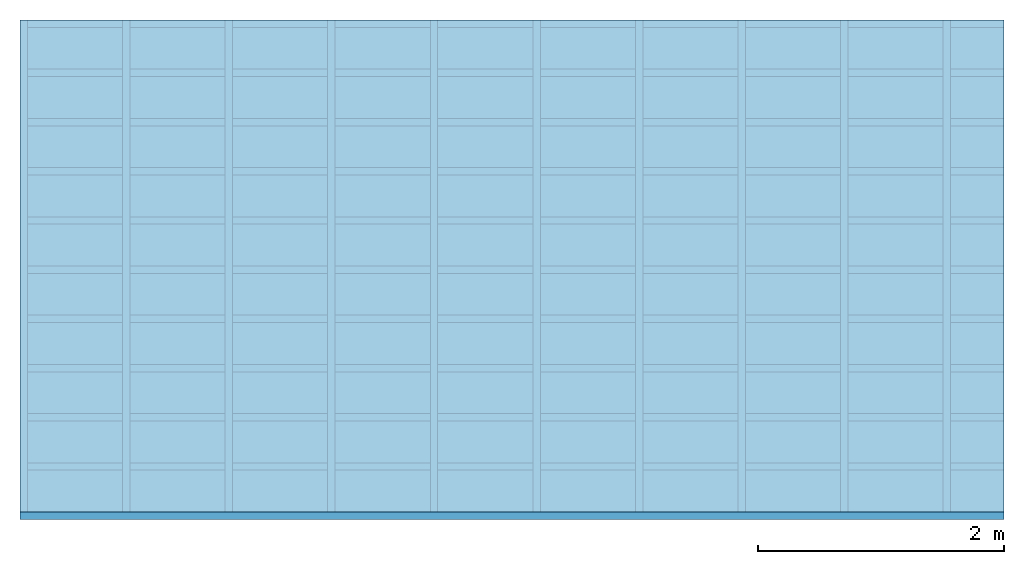
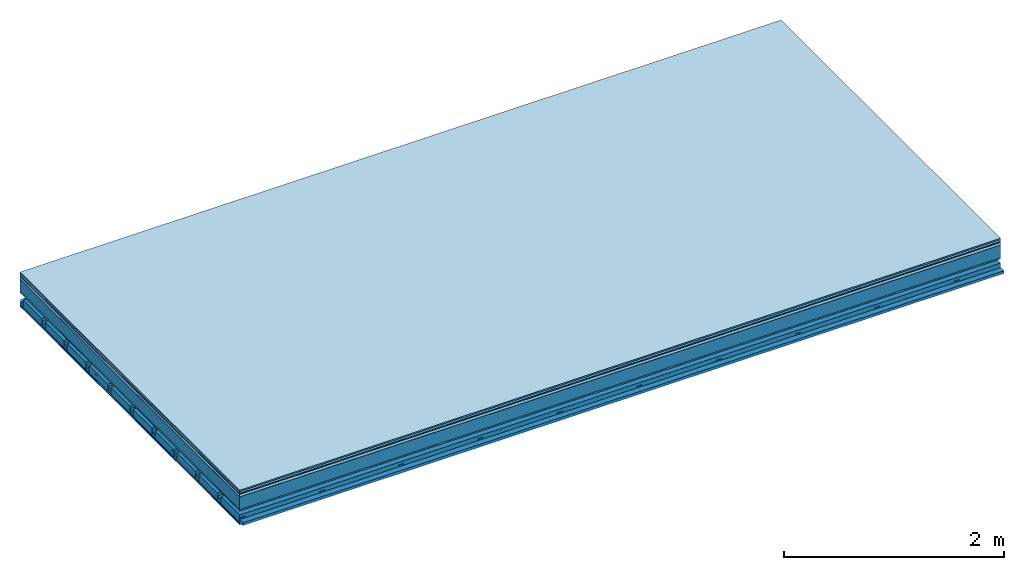
# One storey: 9 plates, 4 members, 1 element without a shape of its own.
"""IFC4 building model written with IfcOpenShell, lengths in metres."""

from ifc_helpers import new_model, si_unit, derived_unit, direction, frame, frame_2d, origin, origin_with_axes, place, context, project, spatial, polyline, rectangle, outline, extrude, material, layer, layer_set, type_object, element, aggregate, save


model = new_model("IFC4")

# Units and contexts
plan_context = context("Plan", 3, precision=1e-05, world=origin(), true_north=direction((0.0, 1.0)))
model_context = context("Model", 3, precision=1e-05, world=origin(), true_north=direction((0.0, 1.0)))
ifc_project = project(units=[si_unit("LENGTHUNIT", "METRE"), derived_unit("SOUNDPRESSUREUNIT", [(si_unit("PRESSUREUNIT", "PASCAL", prefix="MICRO"), 0)]), si_unit("ENERGYUNIT", "JOULE", prefix="MEGA"), si_unit("MASSUNIT", "GRAM", prefix="KILO"), derived_unit("THERMALTRANSMITTANCEUNIT", [(si_unit("POWERUNIT", "WATT"), 1), (si_unit("AREAUNIT", "SQUARE_METRE"), -1), (si_unit("THERMODYNAMICTEMPERATUREUNIT", "KELVIN"), -1)]), derived_unit("AREADENSITYUNIT", [(si_unit("MASSUNIT", "GRAM", prefix="KILO"), 1), (si_unit("AREAUNIT", "SQUARE_METRE"), -1)]), derived_unit("USERDEFINED", [(si_unit("ENERGYUNIT", "JOULE", prefix="MEGA"), 1), (si_unit("AREAUNIT", "SQUARE_METRE"), -1)])], contexts=[plan_context, model_context])

# Site, building, storey
site = spatial("IfcSite", under=ifc_project)
building_placement = place(None, origin())
building = spatial("IfcBuilding", under=site, at=building_placement)
storey_placement = place(building_placement, origin())
storey = spatial("IfcBuildingStorey", under=building, at=storey_placement)

# Slab, members, plates
ifc_material_1 = material(Category="11.013")
ifc_layer_1 = layer(ifc_material_1, 0.015, Name="Flooring")
ifc_material_2 = material(Category="03.007")
ifc_layer_2 = layer(ifc_material_2, 0.02, Name="On-material")
ifc_material_3 = material(Name="Wood fiber generic product", Category="10.009")
ifc_layer_3 = layer(ifc_material_3, 0.01, Name="Impact sound insulation")
ifc_material_4 = material(Name="with broken")
ifc_layer_4 = layer(ifc_material_4, 0.03, Name="on Supporting structure")
ifc_material_5 = material(Name="protection", Category="09.007")
ifc_layer_5 = layer(ifc_material_5, 0.0005, Name="Sub-floor")
ifc_material_6 = material(Name="no composite action")
ifc_layer_6 = layer(ifc_material_6, 0.0, Name="Bond")
ifc_layer_7 = layer(None, 0.14, Name="Supporting structure")
ifc_material_7 = material(Name="of the art")
ifc_layer_8 = layer(ifc_material_7, 0.0, Name="Bond")
ifc_layer_9 = layer(ifc_material_2, 0.015, Name="Lower layer 1")
ifc_layer_10 = layer(None, 0.095, Name="Coupling")
ifc_layer_11 = layer(None, 0.03, Name="Battens / profiles")
ifc_material_8 = material(Name="Plasterboard type A", Category="03.008")
ifc_layer_12 = layer(ifc_material_8, 0.0125, Name="Ceiling covering 1st layer")
ifc_layer_13 = layer(ifc_material_8, 0.0125, Name="Ceiling covering layer 2")
ifc_material_9 = material(Category="04.001")
ifc_layer_14 = layer(ifc_material_9, 0.003, Name="Surface / treatment")
ifc_layer_set = layer_set([ifc_layer_1, ifc_layer_2, ifc_layer_3, ifc_layer_4, ifc_layer_5, ifc_layer_6, ifc_layer_7, ifc_layer_8, ifc_layer_9, ifc_layer_10, ifc_layer_11, ifc_layer_12, ifc_layer_13, ifc_layer_14])
slab_type = type_object("IfcSlabType", Name="A2124", PredefinedType="NOTDEFINED", material=ifc_layer_set)
slab_placement = place(None, frame((0.0, 0.0, 0.0), z_axis=(0.0, 0.0, -1.0), x_axis=(1.0, 0.0, 0.0)))
slab = element("IfcSlab", 1, at=slab_placement, inside=storey, type_object=slab_type, material=ifc_layer_set, Name="Slab #1")
ifc_material_10 = material(Name="Solid timber panel")
member_1_placement = place(slab_placement, origin())
member_1 = element("IfcMember", 2, at=member_1_placement, material=ifc_material_10, Name="Supporting structure", context=plan_context, shape_type="SweptSolid", body=[
    extrude(rectangle(XDim=1.0, YDim=0.14, at=frame_2d((0.5, 0.07), x_axis=(1.0, 0.0))), frame((0.0, 4.0, 0.0755), z_axis=(0.0, -1.0, 0.0), x_axis=(1.0, 0.0, 0.0)), (0.0, 0.0, 1.0), 4.0),
    extrude(rectangle(XDim=1.0, YDim=0.14, at=frame_2d((0.5, 0.07), x_axis=(1.0, 0.0))), frame((1.0, 4.0, 0.0755), z_axis=(0.0, -1.0, 0.0), x_axis=(1.0, 0.0, 0.0)), (0.0, 0.0, 1.0), 4.0),
    extrude(rectangle(XDim=1.0, YDim=0.14, at=frame_2d((0.5, 0.07), x_axis=(1.0, 0.0))), frame((2.0, 4.0, 0.0755), z_axis=(0.0, -1.0, 0.0), x_axis=(1.0, 0.0, 0.0)), (0.0, 0.0, 1.0), 4.0),
    extrude(rectangle(XDim=1.0, YDim=0.14, at=frame_2d((0.5, 0.07), x_axis=(1.0, 0.0))), frame((3.0, 4.0, 0.0755), z_axis=(0.0, -1.0, 0.0), x_axis=(1.0, 0.0, 0.0)), (0.0, 0.0, 1.0), 4.0),
    extrude(rectangle(XDim=1.0, YDim=0.14, at=frame_2d((0.5, 0.07), x_axis=(1.0, 0.0))), frame((4.0, 4.0, 0.0755), z_axis=(0.0, -1.0, 0.0), x_axis=(1.0, 0.0, 0.0)), (0.0, 0.0, 1.0), 4.0),
    extrude(rectangle(XDim=1.0, YDim=0.14, at=frame_2d((0.5, 0.07), x_axis=(1.0, 0.0))), frame((5.0, 4.0, 0.0755), z_axis=(0.0, -1.0, 0.0), x_axis=(1.0, 0.0, 0.0)), (0.0, 0.0, 1.0), 4.0),
    extrude(rectangle(XDim=1.0, YDim=0.14, at=frame_2d((0.5, 0.07), x_axis=(1.0, 0.0))), frame((6.0, 4.0, 0.0755), z_axis=(0.0, -1.0, 0.0), x_axis=(1.0, 0.0, 0.0)), (0.0, 0.0, 1.0), 4.0),
    extrude(rectangle(XDim=1.0, YDim=0.14, at=frame_2d((0.5, 0.07), x_axis=(1.0, 0.0))), frame((7.0, 4.0, 0.0755), z_axis=(0.0, -1.0, 0.0), x_axis=(1.0, 0.0, 0.0)), (0.0, 0.0, 1.0), 4.0),
])
ifc_material_11 = material()
member_2_placement = place(slab_placement, origin())
member_2 = element("IfcMember", 3, at=member_2_placement, material=ifc_material_11, Name="Coupling", context=plan_context, shape_type="SweptSolid", body=[
    extrude(outline(polyline([(0.0, 0.0), (0.06, 0.0), (0.04, 0.02), (0.02, 0.02), (0.0, 0.0)])), frame((0.0, 4.0, 0.3055), z_axis=(0.0, -1.0, 0.0), x_axis=(1.0, 0.0, 0.0)), (0.0, 0.0, 1.0), 4.0),
    extrude(outline(polyline([(0.0, 0.0), (0.06, 0.0), (0.04, 0.02), (0.02, 0.02), (0.0, 0.0)])), frame((0.834, 4.0, 0.3055), z_axis=(0.0, -1.0, 0.0), x_axis=(1.0, 0.0, 0.0)), (0.0, 0.0, 1.0), 4.0),
    extrude(outline(polyline([(0.0, 0.0), (0.06, 0.0), (0.04, 0.02), (0.02, 0.02), (0.0, 0.0)])), frame((1.668, 4.0, 0.3055), z_axis=(0.0, -1.0, 0.0), x_axis=(1.0, 0.0, 0.0)), (0.0, 0.0, 1.0), 4.0),
    extrude(outline(polyline([(0.0, 0.0), (0.06, 0.0), (0.04, 0.02), (0.02, 0.02), (0.0, 0.0)])), frame((2.502, 4.0, 0.3055), z_axis=(0.0, -1.0, 0.0), x_axis=(1.0, 0.0, 0.0)), (0.0, 0.0, 1.0), 4.0),
    extrude(outline(polyline([(0.0, 0.0), (0.06, 0.0), (0.04, 0.02), (0.02, 0.02), (0.0, 0.0)])), frame((3.336, 4.0, 0.3055), z_axis=(0.0, -1.0, 0.0), x_axis=(1.0, 0.0, 0.0)), (0.0, 0.0, 1.0), 4.0),
    extrude(outline(polyline([(0.0, 0.0), (0.06, 0.0), (0.04, 0.02), (0.02, 0.02), (0.0, 0.0)])), frame((4.17, 4.0, 0.3055), z_axis=(0.0, -1.0, 0.0), x_axis=(1.0, 0.0, 0.0)), (0.0, 0.0, 1.0), 4.0),
    extrude(outline(polyline([(0.0, 0.0), (0.06, 0.0), (0.04, 0.02), (0.02, 0.02), (0.0, 0.0)])), frame((5.004, 4.0, 0.3055), z_axis=(0.0, -1.0, 0.0), x_axis=(1.0, 0.0, 0.0)), (0.0, 0.0, 1.0), 4.0),
    extrude(outline(polyline([(0.0, 0.0), (0.06, 0.0), (0.04, 0.02), (0.02, 0.02), (0.0, 0.0)])), frame((5.838, 4.0, 0.3055), z_axis=(0.0, -1.0, 0.0), x_axis=(1.0, 0.0, 0.0)), (0.0, 0.0, 1.0), 4.0),
    extrude(outline(polyline([(0.0, 0.0), (0.06, 0.0), (0.04, 0.02), (0.02, 0.02), (0.0, 0.0)])), frame((6.672, 4.0, 0.3055), z_axis=(0.0, -1.0, 0.0), x_axis=(1.0, 0.0, 0.0)), (0.0, 0.0, 1.0), 4.0),
    extrude(outline(polyline([(0.0, 0.0), (0.06, 0.0), (0.04, 0.02), (0.02, 0.02), (0.0, 0.0)])), frame((7.506, 4.0, 0.3055), z_axis=(0.0, -1.0, 0.0), x_axis=(1.0, 0.0, 0.0)), (0.0, 0.0, 1.0), 4.0),
])
member_3_placement = place(slab_placement, origin())
member_3 = element("IfcMember", 4, at=member_3_placement, material=ifc_material_11, Name="Battens / profiles", context=plan_context, shape_type="SweptSolid", body=[
    extrude(rectangle(XDim=0.06, YDim=0.03, at=frame_2d((0.03, 0.015), x_axis=(1.0, 0.0))), frame((0.0, 0.0, 0.3255), z_axis=(1.0, 0.0, 0.0), x_axis=(0.0, 1.0, 0.0)), (0.0, 0.0, 1.0), 8.0),
    extrude(rectangle(XDim=0.06, YDim=0.03, at=frame_2d((0.03, 0.015), x_axis=(1.0, 0.0))), frame((0.0, 0.4, 0.3255), z_axis=(1.0, 0.0, 0.0), x_axis=(0.0, 1.0, 0.0)), (0.0, 0.0, 1.0), 8.0),
    extrude(rectangle(XDim=0.06, YDim=0.03, at=frame_2d((0.03, 0.015), x_axis=(1.0, 0.0))), frame((0.0, 0.8, 0.3255), z_axis=(1.0, 0.0, 0.0), x_axis=(0.0, 1.0, 0.0)), (0.0, 0.0, 1.0), 8.0),
    extrude(rectangle(XDim=0.06, YDim=0.03, at=frame_2d((0.03, 0.015), x_axis=(1.0, 0.0))), frame((0.0, 1.2, 0.3255), z_axis=(1.0, 0.0, 0.0), x_axis=(0.0, 1.0, 0.0)), (0.0, 0.0, 1.0), 8.0),
    extrude(rectangle(XDim=0.06, YDim=0.03, at=frame_2d((0.03, 0.015), x_axis=(1.0, 0.0))), frame((0.0, 1.6, 0.3255), z_axis=(1.0, 0.0, 0.0), x_axis=(0.0, 1.0, 0.0)), (0.0, 0.0, 1.0), 8.0),
    extrude(rectangle(XDim=0.06, YDim=0.03, at=frame_2d((0.03, 0.015), x_axis=(1.0, 0.0))), frame((0.0, 2.0, 0.3255), z_axis=(1.0, 0.0, 0.0), x_axis=(0.0, 1.0, 0.0)), (0.0, 0.0, 1.0), 8.0),
    extrude(rectangle(XDim=0.06, YDim=0.03, at=frame_2d((0.03, 0.015), x_axis=(1.0, 0.0))), frame((0.0, 2.4, 0.3255), z_axis=(1.0, 0.0, 0.0), x_axis=(0.0, 1.0, 0.0)), (0.0, 0.0, 1.0), 8.0),
    extrude(rectangle(XDim=0.06, YDim=0.03, at=frame_2d((0.03, 0.015), x_axis=(1.0, 0.0))), frame((0.0, 2.8, 0.3255), z_axis=(1.0, 0.0, 0.0), x_axis=(0.0, 1.0, 0.0)), (0.0, 0.0, 1.0), 8.0),
    extrude(rectangle(XDim=0.06, YDim=0.03, at=frame_2d((0.03, 0.015), x_axis=(1.0, 0.0))), frame((0.0, 3.2, 0.3255), z_axis=(1.0, 0.0, 0.0), x_axis=(0.0, 1.0, 0.0)), (0.0, 0.0, 1.0), 8.0),
    extrude(rectangle(XDim=0.06, YDim=0.03, at=frame_2d((0.03, 0.015), x_axis=(1.0, 0.0))), frame((0.0, 3.6, 0.3255), z_axis=(1.0, 0.0, 0.0), x_axis=(0.0, 1.0, 0.0)), (0.0, 0.0, 1.0), 8.0),
    extrude(rectangle(XDim=0.06, YDim=0.03, at=frame_2d((0.03, 0.015), x_axis=(1.0, 0.0))), frame((0.0, 4.0, 0.3255), z_axis=(1.0, 0.0, 0.0), x_axis=(0.0, 1.0, 0.0)), (0.0, 0.0, 1.0), 8.0),
])
ifc_material_12 = material()
member_4_placement = place(slab_placement, origin())
member_4 = element("IfcMember", 5, at=member_4_placement, material=ifc_material_12, Name="Cavity", context=plan_context, shape_type="SweptSolid", body=[
    extrude(rectangle(XDim=0.34, YDim=0.08, at=frame_2d((0.17, 0.04), x_axis=(1.0, 0.0))), frame((0.0, 0.06, 0.2755), z_axis=(1.0, 0.0, 0.0), x_axis=(0.0, 1.0, 0.0)), (0.0, 0.0, 1.0), 8.0),
    extrude(rectangle(XDim=0.34, YDim=0.08, at=frame_2d((0.17, 0.04), x_axis=(1.0, 0.0))), frame((0.0, 0.46, 0.2755), z_axis=(1.0, 0.0, 0.0), x_axis=(0.0, 1.0, 0.0)), (0.0, 0.0, 1.0), 8.0),
    extrude(rectangle(XDim=0.34, YDim=0.08, at=frame_2d((0.17, 0.04), x_axis=(1.0, 0.0))), frame((0.0, 0.86, 0.2755), z_axis=(1.0, 0.0, 0.0), x_axis=(0.0, 1.0, 0.0)), (0.0, 0.0, 1.0), 8.0),
    extrude(rectangle(XDim=0.34, YDim=0.08, at=frame_2d((0.17, 0.04), x_axis=(1.0, 0.0))), frame((0.0, 1.26, 0.2755), z_axis=(1.0, 0.0, 0.0), x_axis=(0.0, 1.0, 0.0)), (0.0, 0.0, 1.0), 8.0),
    extrude(rectangle(XDim=0.34, YDim=0.08, at=frame_2d((0.17, 0.04), x_axis=(1.0, 0.0))), frame((0.0, 1.66, 0.2755), z_axis=(1.0, 0.0, 0.0), x_axis=(0.0, 1.0, 0.0)), (0.0, 0.0, 1.0), 8.0),
    extrude(rectangle(XDim=0.34, YDim=0.08, at=frame_2d((0.17, 0.04), x_axis=(1.0, 0.0))), frame((0.0, 2.06, 0.2755), z_axis=(1.0, 0.0, 0.0), x_axis=(0.0, 1.0, 0.0)), (0.0, 0.0, 1.0), 8.0),
    extrude(rectangle(XDim=0.34, YDim=0.08, at=frame_2d((0.17, 0.04), x_axis=(1.0, 0.0))), frame((0.0, 2.46, 0.2755), z_axis=(1.0, 0.0, 0.0), x_axis=(0.0, 1.0, 0.0)), (0.0, 0.0, 1.0), 8.0),
    extrude(rectangle(XDim=0.34, YDim=0.08, at=frame_2d((0.17, 0.04), x_axis=(1.0, 0.0))), frame((0.0, 2.86, 0.2755), z_axis=(1.0, 0.0, 0.0), x_axis=(0.0, 1.0, 0.0)), (0.0, 0.0, 1.0), 8.0),
    extrude(rectangle(XDim=0.34, YDim=0.08, at=frame_2d((0.17, 0.04), x_axis=(1.0, 0.0))), frame((0.0, 3.26, 0.2755), z_axis=(1.0, 0.0, 0.0), x_axis=(0.0, 1.0, 0.0)), (0.0, 0.0, 1.0), 8.0),
    extrude(rectangle(XDim=0.34, YDim=0.08, at=frame_2d((0.17, 0.04), x_axis=(1.0, 0.0))), frame((0.0, 3.66, 0.2755), z_axis=(1.0, 0.0, 0.0), x_axis=(0.0, 1.0, 0.0)), (0.0, 0.0, 1.0), 8.0),
])
plate_1_placement = place(slab_placement, origin())
plate_1 = element("IfcPlate", 6, at=plate_1_placement, material=ifc_material_1, Name="Flooring", context=plan_context, shape_type="SweptSolid", body=[
    extrude(rectangle(XDim=8.0, YDim=4.0, at=frame_2d((4.0, 2.0), x_axis=(1.0, 0.0))), origin_with_axes(), (0.0, 0.0, 1.0), 0.015),
])
plate_2_placement = place(slab_placement, origin())
plate_2 = element("IfcPlate", 7, at=plate_2_placement, material=ifc_material_2, Name="On-material", context=plan_context, shape_type="SweptSolid", body=[
    extrude(rectangle(XDim=8.0, YDim=4.0, at=frame_2d((4.0, 2.0), x_axis=(1.0, 0.0))), frame((0.0, 0.0, 0.015), z_axis=(0.0, 0.0, 1.0), x_axis=(1.0, 0.0, 0.0)), (0.0, 0.0, 1.0), 0.02),
])
plate_3_placement = place(slab_placement, origin())
plate_3 = element("IfcPlate", 8, at=plate_3_placement, material=ifc_material_3, Name="Impact sound insulation", context=plan_context, shape_type="SweptSolid", body=[
    extrude(rectangle(XDim=8.0, YDim=4.0, at=frame_2d((4.0, 2.0), x_axis=(1.0, 0.0))), frame((0.0, 0.0, 0.035), z_axis=(0.0, 0.0, 1.0), x_axis=(1.0, 0.0, 0.0)), (0.0, 0.0, 1.0), 0.01),
])
plate_4_placement = place(slab_placement, origin())
plate_4 = element("IfcPlate", 9, at=plate_4_placement, material=ifc_material_4, Name="on Supporting structure", context=plan_context, shape_type="SweptSolid", body=[
    extrude(rectangle(XDim=8.0, YDim=4.0, at=frame_2d((4.0, 2.0), x_axis=(1.0, 0.0))), frame((0.0, 0.0, 0.045), z_axis=(0.0, 0.0, 1.0), x_axis=(1.0, 0.0, 0.0)), (0.0, 0.0, 1.0), 0.03),
])
plate_5_placement = place(slab_placement, origin())
plate_5 = element("IfcPlate", 10, at=plate_5_placement, material=ifc_material_5, Name="Sub-floor", context=plan_context, shape_type="SweptSolid", body=[
    extrude(rectangle(XDim=8.0, YDim=4.0, at=frame_2d((4.0, 2.0), x_axis=(1.0, 0.0))), frame((0.0, 0.0, 0.075), z_axis=(0.0, 0.0, 1.0), x_axis=(1.0, 0.0, 0.0)), (0.0, 0.0, 1.0), 0.0005),
])
plate_6_placement = place(slab_placement, origin())
plate_6 = element("IfcPlate", 11, at=plate_6_placement, material=ifc_material_2, Name="Lower layer 1", context=plan_context, shape_type="SweptSolid", body=[
    extrude(rectangle(XDim=8.0, YDim=4.0, at=frame_2d((4.0, 2.0), x_axis=(1.0, 0.0))), frame((0.0, 0.0, 0.2155), z_axis=(0.0, 0.0, 1.0), x_axis=(1.0, 0.0, 0.0)), (0.0, 0.0, 1.0), 0.015),
])
plate_7_placement = place(slab_placement, origin())
plate_7 = element("IfcPlate", 12, at=plate_7_placement, material=ifc_material_8, Name="Ceiling covering 1st layer", context=plan_context, shape_type="SweptSolid", body=[
    extrude(rectangle(XDim=8.0, YDim=4.0, at=frame_2d((4.0, 2.0), x_axis=(1.0, 0.0))), frame((0.0, 0.0, 0.3555), z_axis=(0.0, 0.0, 1.0), x_axis=(1.0, 0.0, 0.0)), (0.0, 0.0, 1.0), 0.0125),
])
plate_8_placement = place(slab_placement, origin())
plate_8 = element("IfcPlate", 13, at=plate_8_placement, material=ifc_material_8, Name="Ceiling covering layer 2", context=plan_context, shape_type="SweptSolid", body=[
    extrude(rectangle(XDim=8.0, YDim=4.0, at=frame_2d((4.0, 2.0), x_axis=(1.0, 0.0))), frame((0.0, 0.0, 0.368), z_axis=(0.0, 0.0, 1.0), x_axis=(1.0, 0.0, 0.0)), (0.0, 0.0, 1.0), 0.0125),
])
plate_9_placement = place(slab_placement, origin())
plate_9 = element("IfcPlate", 14, at=plate_9_placement, material=ifc_material_9, Name="Surface / treatment", context=plan_context, shape_type="SweptSolid", body=[
    extrude(rectangle(XDim=8.0, YDim=4.0, at=frame_2d((4.0, 2.0), x_axis=(1.0, 0.0))), frame((0.0, 0.0, 0.3805), z_axis=(0.0, 0.0, 1.0), x_axis=(1.0, 0.0, 0.0)), (0.0, 0.0, 1.0), 0.003),
])
aggregate(slab, [plate_1, plate_2, plate_3, plate_4, plate_5, member_1, plate_6, member_2, member_3, member_4, plate_7, plate_8, plate_9])

save(model, "model.ifc")
